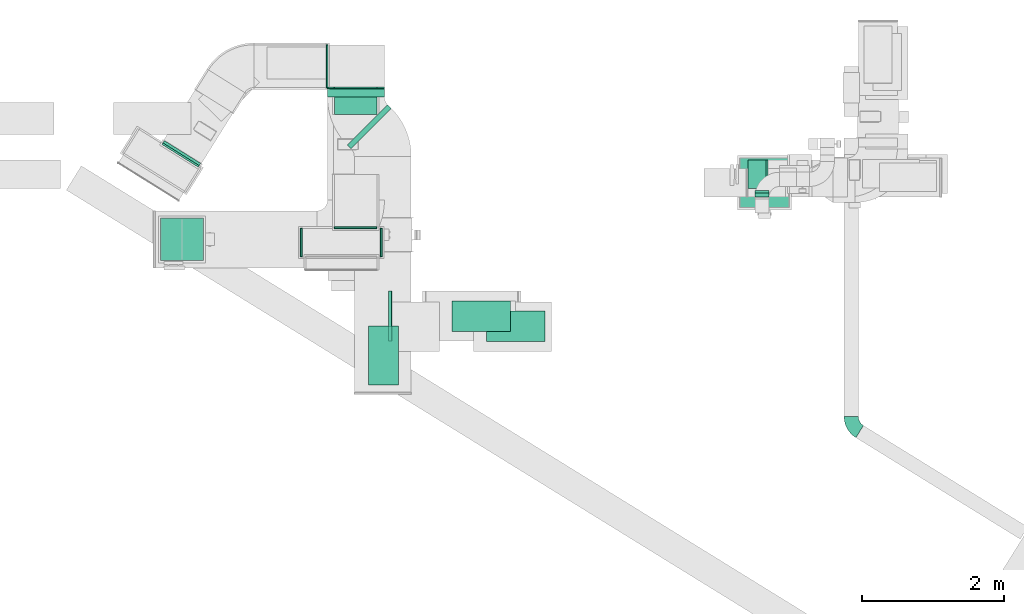
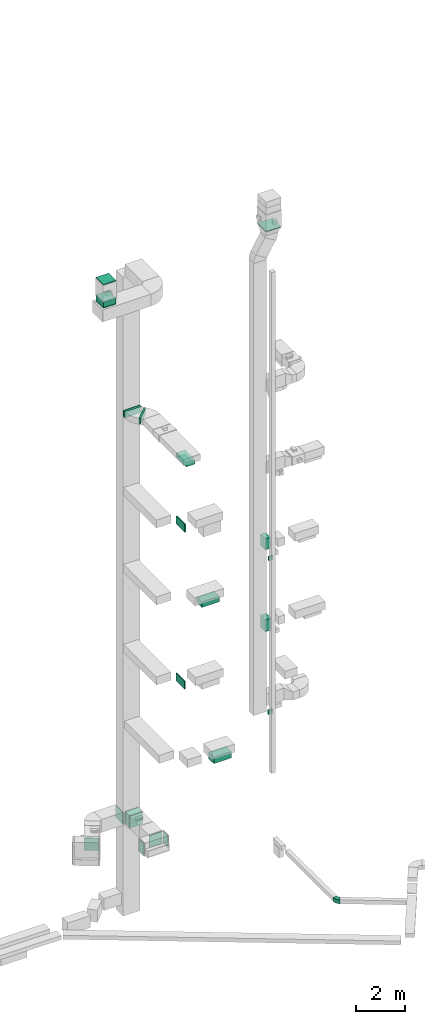
# One storey, part 9 of 25: 16 flow segments, 10 flow fittings, 1 flow terminal.
"""IFC2X3 building model written with IfcOpenShell, lengths in millimetres."""

from ifc_helpers import new_model, entity, si_unit, converted_unit, derived_unit, direction, frame, frame_2d, origin, origin_2d_with_axis, place, context, subcontext, project, spatial, polyline, circle_curve, parameter, trimmed, segment, composite_curve, rectangle, outline, extrude, source, transform, mapped, material, type_object, type_shapes, element, save


model = new_model("IFC2X3")

# Units and contexts
model_context = context("Model", 3, precision=0.01, world=origin(), true_north=direction((6.12303176911189e-17, 1.0)))
body_context = subcontext(model_context, "Body", "Model", "MODEL_VIEW")
ifc_project = project(units=[si_unit("LENGTHUNIT", "METRE", prefix="MILLI"), si_unit("AREAUNIT", "SQUARE_METRE"), si_unit("VOLUMEUNIT", "CUBIC_METRE"), converted_unit("PLANEANGLEUNIT", "DEGREE", entity("IfcRatioMeasure", 0.0174532925199433), si_unit("PLANEANGLEUNIT", "RADIAN"), dimensions=[0, 0, 0, 0, 0, 0, 0]), si_unit("MASSUNIT", "GRAM", prefix="KILO"), derived_unit("MASSDENSITYUNIT", [(si_unit("MASSUNIT", "GRAM", prefix="KILO"), 1), (si_unit("LENGTHUNIT", "METRE"), -3)]), derived_unit("MOMENTOFINERTIAUNIT", [(si_unit("LENGTHUNIT", "METRE"), 4)]), si_unit("TIMEUNIT", "SECOND"), si_unit("FREQUENCYUNIT", "HERTZ"), si_unit("THERMODYNAMICTEMPERATUREUNIT", "DEGREE_CELSIUS"), derived_unit("THERMALTRANSMITTANCEUNIT", [(si_unit("MASSUNIT", "GRAM", prefix="KILO"), 1), (si_unit("THERMODYNAMICTEMPERATUREUNIT", "KELVIN"), -1), (si_unit("TIMEUNIT", "SECOND"), -3)]), derived_unit("VOLUMETRICFLOWRATEUNIT", [(si_unit("LENGTHUNIT", "METRE"), 3), (si_unit("TIMEUNIT", "SECOND"), -1)]), derived_unit("MASSFLOWRATEUNIT", [(si_unit("MASSUNIT", "GRAM", prefix="KILO"), 1), (si_unit("TIMEUNIT", "SECOND"), -1)]), derived_unit("ROTATIONALFREQUENCYUNIT", [(si_unit("TIMEUNIT", "SECOND"), -1)]), si_unit("ELECTRICCURRENTUNIT", "AMPERE"), si_unit("ELECTRICVOLTAGEUNIT", "VOLT"), si_unit("POWERUNIT", "WATT"), si_unit("FORCEUNIT", "NEWTON", prefix="KILO"), si_unit("ILLUMINANCEUNIT", "LUX"), si_unit("LUMINOUSFLUXUNIT", "LUMEN"), si_unit("LUMINOUSINTENSITYUNIT", "CANDELA"), derived_unit("USERDEFINED", [(si_unit("MASSUNIT", "GRAM", prefix="KILO"), -1), (si_unit("LENGTHUNIT", "METRE"), -2), (si_unit("TIMEUNIT", "SECOND"), 3), (si_unit("LUMINOUSFLUXUNIT", "LUMEN"), 1)]), derived_unit("LINEARVELOCITYUNIT", [(si_unit("LENGTHUNIT", "METRE"), 1), (si_unit("TIMEUNIT", "SECOND"), -1)]), si_unit("PRESSUREUNIT", "PASCAL"), derived_unit("USERDEFINED", [(si_unit("LENGTHUNIT", "METRE"), -2), (si_unit("MASSUNIT", "GRAM", prefix="KILO"), 1), (si_unit("TIMEUNIT", "SECOND"), -2)]), derived_unit("LINEARFORCEUNIT", [(si_unit("MASSUNIT", "GRAM", prefix="KILO"), 1), (si_unit("LENGTHUNIT", "METRE"), 1), (si_unit("TIMEUNIT", "SECOND"), -2), (si_unit("LENGTHUNIT", "METRE"), -1)]), derived_unit("PLANARFORCEUNIT", [(si_unit("MASSUNIT", "GRAM", prefix="KILO"), 1), (si_unit("LENGTHUNIT", "METRE"), 1), (si_unit("TIMEUNIT", "SECOND"), -2), (si_unit("LENGTHUNIT", "METRE"), -2)])], contexts=[model_context])

# Site, building, storey
site_placement = place(None, origin())
site = spatial("IfcSite", under=ifc_project, at=site_placement, CompositionType="ELEMENT")
building_placement = place(site_placement, origin())
building = spatial("IfcBuilding", under=site, at=building_placement, CompositionType="ELEMENT")
storey_placement = place(building_placement, origin())
storey = spatial("IfcBuildingStorey", under=building, at=storey_placement, CompositionType="ELEMENT", Elevation=0.0)

# Flow segments
duct_segment_type_1 = type_object("IfcDuctSegmentType", PredefinedType="NOTDEFINED")
flow_segment_1_placement = place(storey_placement, frame((10144.72, 14470.84, 6800.0)))
element("IfcFlowSegment", 1, at=flow_segment_1_placement, inside=storey, type_object=duct_segment_type_1, context=body_context, shape_type="SweptSolid", body=[
    extrude(rectangle(XDim=92.2080871830601, YDim=200.0, at=origin_2d_with_axis()), frame((100.0, 46.1, 0.0), z_axis=(0.0, 0.0, 1.0), x_axis=(0.0, 1.0, 0.0)), (0.0, 0.0, 1.0), 200.0),
])
flow_segment_2_placement = place(storey_placement, frame((10049.73, 14595.08, 10900.0)))
element("IfcFlowSegment", 2, at=flow_segment_2_placement, inside=storey, type_object=duct_segment_type_1, context=body_context, shape_type="SweptSolid", body=[
    extrude(rectangle(XDim=279.999999999941, YDim=400.0, at=origin_2d_with_axis()), frame((140.0, 200.0, 0.0), z_axis=(0.0, 0.0, 1.0), x_axis=(-1.0, 0.0, 0.0)), (0.0, 0.0, 1.0), 599.999999999998),
])
flow_segment_3_placement = place(storey_placement, frame((10049.73, 14594.08, 15000.0)))
element("IfcFlowSegment", 3, at=flow_segment_3_placement, inside=storey, type_object=duct_segment_type_1, context=body_context, shape_type="SweptSolid", body=[
    extrude(rectangle(XDim=253.753141867867, YDim=400.0, at=origin_2d_with_axis()), frame((126.88, 200.0, 0.0), z_axis=(0.0, 0.0, 1.0), x_axis=(-1.0, 0.0, 0.0)), (0.0, 0.0, 1.0), 550.000000000001),
])
flow_segment_4_placement = place(storey_placement, frame((10144.72, 14470.84, 14500.0)))
element("IfcFlowSegment", 4, at=flow_segment_4_placement, inside=storey, type_object=duct_segment_type_1, context=body_context, shape_type="SweptSolid", body=[
    extrude(rectangle(XDim=59.9999999998932, YDim=200.0, at=origin_2d_with_axis()), frame((100.0, 30.0, 0.0), z_axis=(0.0, 0.0, 1.0), x_axis=(0.0, 1.0, 0.0)), (0.0, 0.0, 1.0), 199.999999999998),
])
flow_segment_5_placement = place(storey_placement, frame((9929.73, 14322.56, 31101.98)))
element("IfcFlowSegment", 5, at=flow_segment_5_placement, inside=storey, type_object=duct_segment_type_1, context=body_context, shape_type="SweptSolid", body=[
    extrude(rectangle(XDim=700.000000000001, YDim=699.999999999999, at=origin_2d_with_axis()), frame((350.0, 350.0, 0.0), z_axis=(0.0, 0.0, 1.0), x_axis=(0.0, 1.0, 0.0)), (0.0, 0.0, 1.0), 38.0236689533407),
])
flow_segment_6_placement = place(storey_placement, frame((1799.0, 13577.57, 30620.0)))
element("IfcFlowSegment", 6, at=flow_segment_6_placement, inside=storey, type_object=duct_segment_type_1, context=body_context, shape_type="SweptSolid", body=[
    extrude(rectangle(XDim=600.0, YDim=600.0, at=origin_2d_with_axis()), frame((300.0, 300.0, 0.0), z_axis=(0.0, 0.0, 1.0), x_axis=(0.0, -1.0, 0.0)), (0.0, 0.0, 1.0), 294.999999999989),
])
flow_segment_7_placement = place(storey_placement, frame((1799.0, 13577.57, 31755.0)))
element("IfcFlowSegment", 7, at=flow_segment_7_placement, inside=storey, type_object=duct_segment_type_1, context=body_context, shape_type="SweptSolid", body=[
    extrude(rectangle(XDim=599.999999999996, YDim=600.0, at=origin_2d_with_axis()), frame((300.0, 300.0, 0.0), z_axis=(0.0, 0.0, 1.0), x_axis=(0.0, -1.0, 0.0)), (0.0, 0.0, 1.0), 30.0000000000018),
])
duct_segment_type_2 = type_object("IfcDuctSegmentType", PredefinedType="NOTDEFINED")
flow_segment_8_placement = place(storey_placement, frame((5000.45, 12449.66, 18950.0)))
element("IfcFlowSegment", 8, at=flow_segment_8_placement, inside=storey, type_object=duct_segment_type_2, context=body_context, shape_type="SweptSolid", body=[
    extrude(rectangle(XDim=49.1980317029415, YDim=699.999999999999, at=origin_2d_with_axis()), frame((24.6, 350.0, 0.0)), (0.0, 0.0, 1.0), 400.0),
])
flow_segment_9_placement = place(storey_placement, frame((4999.45, 12449.66, 11100.0)))
element("IfcFlowSegment", 9, at=flow_segment_9_placement, inside=storey, type_object=duct_segment_type_2, context=body_context, shape_type="SweptSolid", body=[
    extrude(rectangle(XDim=40.1980317029457, YDim=699.999999999999, at=origin_2d_with_axis()), frame((20.1, 350.0, 0.0)), (0.0, 0.0, 1.0), 400.0),
])
flow_segment_10_placement = place(storey_placement, frame((5889.69, 12585.16, 14800.0)))
element("IfcFlowSegment", 10, at=flow_segment_10_placement, inside=storey, type_object=duct_segment_type_2, context=body_context, shape_type="SweptSolid", body=[
    extrude(rectangle(XDim=825.000000000001, YDim=425.000000000001, at=origin_2d_with_axis()), frame((412.5, 212.5, 0.0)), (0.0, 0.0, 1.0), 279.999999999988),
])
flow_segment_11_placement = place(storey_placement, frame((6374.71, 12444.66, 6900.0)))
element("IfcFlowSegment", 11, at=flow_segment_11_placement, inside=storey, type_object=duct_segment_type_2, context=body_context, shape_type="SweptSolid", body=[
    extrude(rectangle(XDim=825.0, YDim=425.000000000001, at=origin_2d_with_axis()), frame((412.5, 212.5, 0.0), z_axis=(0.0, 0.0, 1.0), x_axis=(-1.0, 0.0, 0.0)), (0.0, 0.0, 1.0), 329.999999999994),
])
flow_segment_12_placement = place(storey_placement, frame((4238.74, 15631.34, 2500.0)))
element("IfcFlowSegment", 12, at=flow_segment_12_placement, inside=storey, type_object=duct_segment_type_2, context=body_context, shape_type="SweptSolid", body=[
    extrude(rectangle(XDim=358.631341415064, YDim=600.0, at=origin_2d_with_axis()), frame((300.0, 179.32, 0.0), z_axis=(0.0, 0.0, 1.0), x_axis=(0.0, 1.0, 0.0)), (0.0, 0.0, 1.0), 600.0),
])
flow_segment_13_placement = place(storey_placement, frame((4717.16, 11834.48, 22700.0)))
element("IfcFlowSegment", 13, at=flow_segment_13_placement, inside=storey, type_object=duct_segment_type_2, context=body_context, shape_type="SweptSolid", body=[
    extrude(rectangle(XDim=824.999999999999, YDim=425.0, at=origin_2d_with_axis()), frame((212.5, 412.5, 0.0), z_axis=(0.0, 0.0, 1.0), x_axis=(0.0, 1.0, 0.0)), (0.0, 0.0, 1.0), 179.999999999955),
])
flow_segment_14_placement = place(storey_placement, frame((1832.29, 14914.79, 2485.0)))
element("IfcFlowSegment", 14, at=flow_segment_14_placement, inside=storey, type_object=duct_segment_type_2, context=body_context, shape_type="SweptSolid", body=[
    extrude(rectangle(XDim=37.4538722069301, YDim=600.000000000002, at=origin_2d_with_axis()), frame((264.34, 174.86, 0.0), z_axis=(0.0, 0.0, 1.0), x_axis=(-0.529919264328232, -0.848048096097047, 0.0)), (0.0, 0.0, 1.0), 600.0),
])
flow_segment_15_placement = place(storey_placement, frame((4421.58, 15149.86, 22900.0)))
element("IfcFlowSegment", 15, at=flow_segment_15_placement, inside=storey, type_object=duct_segment_type_2, context=body_context, shape_type="SweptSolid", body=[
    extrude(rectangle(XDim=76.5778291089947, YDim=800.0, at=origin_2d_with_axis()), frame((309.92, 309.92, 0.0), z_axis=(0.0, 0.0, 1.0), x_axis=(-0.707106781186724, 0.707106781186371, 0.0)), (0.0, 0.0, 1.0), 300.000000000001),
])
flow_segment_16_placement = place(storey_placement, frame((4143.33, 15875.76, 22900.0)))
element("IfcFlowSegment", 16, at=flow_segment_16_placement, inside=storey, type_object=duct_segment_type_2, context=body_context, shape_type="SweptSolid", body=[
    extrude(rectangle(XDim=114.218183383578, YDim=800.0, at=origin_2d_with_axis()), frame((400.0, 57.11, 0.0), z_axis=(0.0, 0.0, 1.0), x_axis=(0.0, 1.0, 0.0)), (0.0, 0.0, 1.0), 300.000000000001),
])

# Flow fittings
ifc_material_1 = material()
duct_fitting_type_1 = type_object("IfcDuctFittingType", PredefinedType="NOTDEFINED", material=ifc_material_1)
shared_shape_1 = source(origin(), body_context, "Body", "SweptSolid", [
    extrude(rectangle(XDim=24.9999999999999, YDim=400.0, at=origin_2d_with_axis()), frame((12.5, 0.0, -300.0)), (0.0, 0.0, 1.0), 600.0),
])
type_shapes(duct_fitting_type_1, [shared_shape_1])
flow_fitting_1_placement = place(storey_placement, frame((3785.85, 13832.5, 2800.0), z_axis=(0.0, 0.0, 1.0), x_axis=(-1.0, 0.0, 0.0)))
element("IfcFlowFitting", 17, at=flow_fitting_1_placement, inside=storey, type_object=duct_fitting_type_1, material=ifc_material_1, context=body_context, shape_type="MappedRepresentation", body=[
    mapped(shared_shape_1, transform((0.0, 0.0, 0.0), scale=1.0)),
])
flow_fitting_2_placement = place(storey_placement, frame((4885.85, 13832.5, 2800.0)))
element("IfcFlowFitting", 18, at=flow_fitting_2_placement, inside=storey, type_object=duct_fitting_type_1, material=ifc_material_1, context=body_context, shape_type="MappedRepresentation", body=[
    mapped(shared_shape_1, transform((0.0, 0.0, 0.0), scale=1.0)),
])
duct_fitting_type_2 = type_object("IfcDuctFittingType", PredefinedType="NOTDEFINED", material=ifc_material_1)
shared_shape_2 = source(origin(), body_context, "Body", "SweptSolid", [
    extrude(rectangle(XDim=26.0960000000009, YDim=600.0, at=origin_2d_with_axis()), frame((6.95, 0.0, -300.0)), (0.0, 0.0, 1.0), 600.0),
])
type_shapes(duct_fitting_type_2, [shared_shape_2])
for number, where, z_axis, x_axis in (
    (19, (4143.33, 16309.98, 2785.0), (0.0, 1.0, 0.0), (-1.0, 0.0, 0.0)),
    (20, (4538.74, 16009.98, 2800.0), (-1.0, 0.0, 0.0), (0.0, -1.0, 0.0)),
    (21, (4538.74, 14032.5, 2800.0), (0.0, 0.0, -1.0), (0.0, 1.0, 0.0)),
):
    element("IfcFlowFitting", number, at=place(storey_placement, frame(where, z_axis=z_axis, x_axis=x_axis)), inside=storey, type_object=duct_fitting_type_2, material=ifc_material_1, context=body_context, shape_type="MappedRepresentation", body=[
        mapped(shared_shape_2, transform((0.0, 0.0, 0.0), scale=1.0)),
    ])
duct_fitting_type_3 = type_object("IfcDuctFittingType", PredefinedType="NOTDEFINED", material=ifc_material_1)
shared_shape_3 = source(origin(), body_context, "Body", "SweptSolid", [
    extrude(rectangle(XDim=600.0, YDim=26.0960000000043, at=origin_2d_with_axis()), frame((6.95, 0.0, -300.0), z_axis=(0.0, 0.0, 1.0), x_axis=(0.0, -1.0, 0.0)), (0.0, 0.0, 1.0), 600.0),
])
type_shapes(duct_fitting_type_3, [shared_shape_3])
flow_fitting_3_placement = place(storey_placement, frame((2099.0, 13877.57, 30600.0), z_axis=(0.0, -1.0, 0.0), x_axis=(0.0, 0.0, 1.0)))
element("IfcFlowFitting", 22, at=flow_fitting_3_placement, inside=storey, type_object=duct_fitting_type_3, material=ifc_material_1, context=body_context, shape_type="MappedRepresentation", body=[
    mapped(shared_shape_3, transform((0.0, 0.0, 0.0), scale=1.0)),
])
duct_fitting_type_4 = type_object("IfcDuctFittingType", PredefinedType="NOTDEFINED", material=ifc_material_1)
shared_shape_4 = source(origin(), body_context, "Body", "SweptSolid", [
    extrude(rectangle(XDim=26.0960000000156, YDim=300.0, at=origin_2d_with_axis()), frame((6.95, 0.0, -400.0)), (0.0, 0.0, 1.0), 800.0),
])
type_shapes(duct_fitting_type_4, [shared_shape_4])
flow_fitting_4_placement = place(storey_placement, frame((4543.33, 16009.98, 23050.0), z_axis=(-1.0, 0.0, 0.0), x_axis=(0.0, -1.0, 0.0)))
element("IfcFlowFitting", 23, at=flow_fitting_4_placement, inside=storey, type_object=duct_fitting_type_4, material=ifc_material_1, context=body_context, shape_type="MappedRepresentation", body=[
    mapped(shared_shape_4, transform((0.0, 0.0, 0.0), scale=1.0)),
])

# Flow terminal
ifc_material_2 = material()
air_terminal_type = type_object("IfcAirTerminalType", PredefinedType="NOTDEFINED", material=ifc_material_2)
shared_shape_5 = source(origin(), body_context, "Body", "SweptSolid", [
    extrude(rectangle(XDim=4.0, YDim=824.999999999999, at=origin_2d_with_axis()), frame((0.0, -2.0, -212.5), z_axis=(0.0, 0.0, 1.0), x_axis=(0.0, 1.0, 0.0)), (0.0, 0.0, 1.0), 425.000000000005),
])
type_shapes(air_terminal_type, [shared_shape_5])
flow_terminal_placement = place(storey_placement, frame((4929.66, 12246.98, 22700.0), z_axis=(1.0, 0.0, 0.0), x_axis=(0.0, 1.0, 0.0)))
element("IfcFlowTerminal", 24, at=flow_terminal_placement, inside=storey, type_object=air_terminal_type, material=ifc_material_2, context=body_context, shape_type="MappedRepresentation", body=[
    mapped(shared_shape_5, transform((0.0, 0.0, 0.0), scale=1.0)),
])

# Flow fittings
duct_fitting_type_5 = type_object("IfcDuctFittingType", PredefinedType="NOTDEFINED", material=ifc_material_1)
shared_shape_6 = source(origin(), body_context, "Body", "SweptSolid", [
    extrude(rectangle(XDim=825.0, YDim=26.0960000000087, at=origin_2d_with_axis()), frame((6.95, 0.0, -212.5), z_axis=(0.0, 0.0, 1.0), x_axis=(0.0, -1.0, 0.0)), (0.0, 0.0, 1.0), 425.0),
])
type_shapes(duct_fitting_type_5, [shared_shape_6])
flow_fitting_5_placement = place(storey_placement, frame((4929.66, 12246.98, 22900.0), z_axis=(-1.0, 0.0, 0.0), x_axis=(0.0, 0.0, -1.0)))
element("IfcFlowFitting", 25, at=flow_fitting_5_placement, inside=storey, type_object=duct_fitting_type_5, material=ifc_material_1, context=body_context, shape_type="MappedRepresentation", body=[
    mapped(shared_shape_6, transform((0.0, 0.0, 0.0), scale=1.0)),
])
duct_fitting_type_6 = type_object("IfcDuctFittingType", PredefinedType="NOTDEFINED", material=ifc_material_1)
shared_shape_7 = source(origin(), body_context, "Body", "SweptSolid", [
    extrude(rectangle(XDim=26.0960001864425, YDim=600.0, at=origin_2d_with_axis()), frame((6.95, 0.0, -300.0)), (0.0, 0.0, 1.0), 600.0),
])
type_shapes(duct_fitting_type_6, [shared_shape_7])
flow_fitting_6_placement = place(storey_placement, frame((2076.11, 15056.81, 2785.0), z_axis=(0.848048096097045, -0.529919264328234, 0.0), x_axis=(0.529919264328233, 0.848048096097046, 0.0)))
element("IfcFlowFitting", 26, at=flow_fitting_6_placement, inside=storey, type_object=duct_fitting_type_6, material=ifc_material_1, context=body_context, shape_type="MappedRepresentation", body=[
    mapped(shared_shape_7, transform((0.0, 0.0, 0.0), scale=1.0)),
])
duct_fitting_type_7 = type_object("IfcDuctFittingType", PredefinedType="NOTDEFINED", material=ifc_material_1)
shared_shape_8 = source(origin(), body_context, "Body", "SweptSolid", [
    extrude(outline(composite_curve([segment(polyline([(-159.31, -106.35), (40.69, -106.35)]), True, "CONTINUOUS"), segment(trimmed(circle_curve(frame_2d((190.69, -106.35), x_axis=(-0.525516588016195, 0.850783354162388)), 150.0), [parameter(0.0)], [parameter(58.2969737827834)], True, "PARAMETER"), False, "CONTINUOUS"), segment(polyline([(111.86, 21.27), (6.76, 191.43)]), True, "CONTINUOUS"), segment(trimmed(circle_curve(frame_2d((190.69, -106.35), x_axis=(-0.525516588016195, 0.850783354162388)), 350.0), [parameter(0.0)], [parameter(58.2969737827834)], True, "PARAMETER"), True, "CONTINUOUS")], self_intersect=False)), frame((-33.08, 59.31, -100.0), z_axis=(0.0, 0.0, 1.0), x_axis=(-0.850783354162395, 0.525516588016197, 0.0)), (0.0, 0.0, 1.0), 200.0),
])
type_shapes(duct_fitting_type_7, [shared_shape_8])
flow_fitting_7_placement = place(storey_placement, frame((11499.83, 11250.5, -1000.0), z_axis=(0.0, 0.0, 1.0), x_axis=(0.0, -1.0, 0.0)))
element("IfcFlowFitting", 27, at=flow_fitting_7_placement, inside=storey, type_object=duct_fitting_type_7, material=ifc_material_1, context=body_context, shape_type="MappedRepresentation", body=[
    mapped(shared_shape_8, transform((0.0, 0.0, 0.0), scale=1.0)),
])

save(model, "model.ifc")
